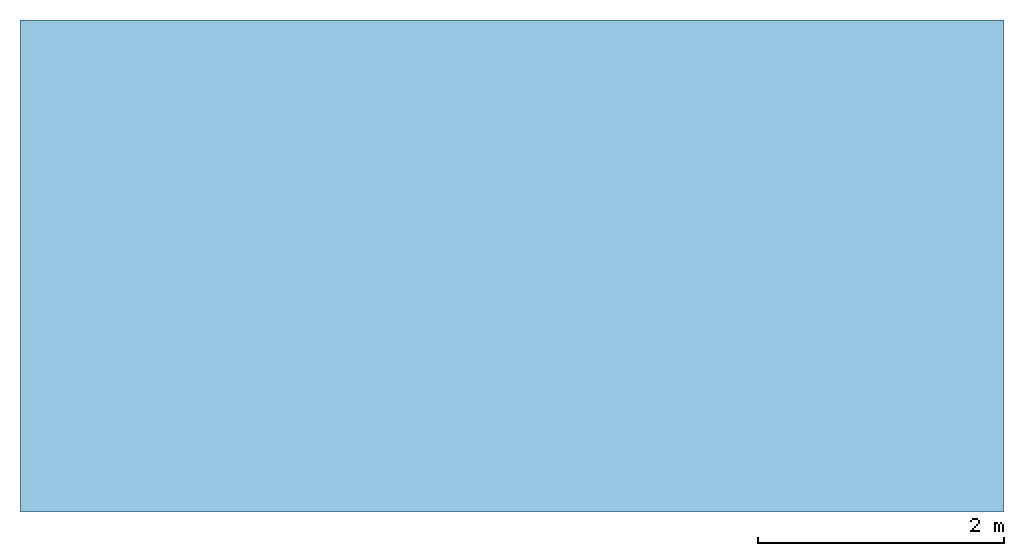
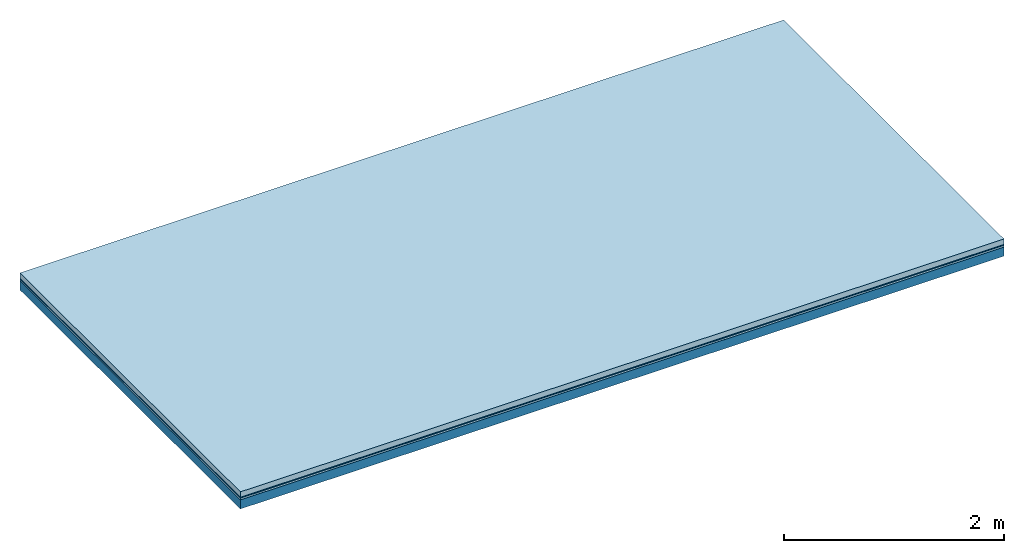
# One storey: 3 plates, 1 member, 1 element without a shape of its own.
"""IFC4 building model written with IfcOpenShell, lengths in metres."""

import ifcopenshell
import ifcopenshell.guid

model = None  # the IFC model being written
_history = None  # IfcOwnerHistory: only IFC2X3 demands one
_inside = {}  # id of a spatial element -> (the spatial element, [elements in it])
_under = {}  # id of a project, library or spatial element -> (it, [spatial elements below it])
_declared = {}  # id of a project -> (the project, [libraries it declares])
_typed = {}  # id of a type object -> (the type object, [elements of that type])
_made_of = {}  # id of a material, layer set ... -> (it, [elements and type objects made of it])


def new_model(schema):
    """Start an empty IFC model of exactly this schema.

    Asked for "IFC4X3", IfcOpenShell would pick the latest addendum, in which some entities
    have other attributes; the version numbers below select the first issue.
    IFC2X3 requires an IfcOwnerHistory on every rooted entity: one is made here for all.
    """
    global model, _history
    if schema == "IFC4X3":
        model = ifcopenshell.file(schema_version=(4, 3, 0, 0))
    else:
        model = ifcopenshell.file(schema=schema)
    _inside.clear()
    _under.clear()
    _declared.clear()
    _typed.clear()
    _made_of.clear()
    _history = None
    if model.schema == "IFC2X3":
        org = make("IfcOrganization", Name="unknown")
        user = make(
            "IfcPersonAndOrganization",
            ThePerson=make("IfcPerson", FamilyName="unknown"),
            TheOrganization=org,
        )
        app = make(
            "IfcApplication",
            ApplicationDeveloper=org,
            Version="unknown",
            ApplicationFullName="unknown",
            ApplicationIdentifier="unknown",
        )
        _history = make(
            "IfcOwnerHistory",
            OwningUser=user,
            OwningApplication=app,
            ChangeAction="ADDED",
            CreationDate=0,
        )
    return model


def make(cls, **values):
    """One entity of the class cls with the attributes given. An attribute that is None is left unset."""
    return model.create_entity(
        cls, **{name: value for name, value in values.items() if value is not None}
    )


def rooted(cls, **values):
    """An entity with a GlobalId (a new one), such as an element, a storey or a relation."""
    return make(cls, GlobalId=ifcopenshell.guid.new(), OwnerHistory=_history, **values)


def si_unit(unit_type, name, prefix=None):
    """IfcSIUnit, for example si_unit("LENGTHUNIT", "METRE", prefix="MILLI")."""
    return make("IfcSIUnit", UnitType=unit_type, Prefix=prefix, Name=name)


def derived_unit(unit_type, elements):
    """IfcDerivedUnit: a product of units, each with its exponent."""
    return make(
        "IfcDerivedUnit",
        Elements=[
            make("IfcDerivedUnitElement", Unit=unit, Exponent=power)
            for unit, power in elements
        ],
        UnitType=unit_type,
    )


def assignment(units):
    """IfcUnitAssignment: the units of a project."""
    return None if units is None else make("IfcUnitAssignment", Units=units)


def point(xyz):
    """IfcCartesianPoint."""
    return None if xyz is None else make("IfcCartesianPoint", Coordinates=xyz)


def direction(xyz):
    """IfcDirection."""
    return None if xyz is None else make("IfcDirection", DirectionRatios=xyz)


def frame(location, z_axis=None, x_axis=None):
    """IfcAxis2Placement3D, a coordinate frame: its origin and axes. An axis left out is left unset."""
    return make(
        "IfcAxis2Placement3D",
        Location=point(location),
        Axis=direction(z_axis),
        RefDirection=direction(x_axis),
    )


def frame_2d(location, x_axis=None):
    """IfcAxis2Placement2D, a coordinate frame in the plane: its origin and x axis."""
    return make(
        "IfcAxis2Placement2D", Location=point(location), RefDirection=direction(x_axis)
    )


def origin():
    """The frame at (0, 0, 0) with its axes left unset."""
    return frame((0.0, 0.0, 0.0))


def origin_with_axes():
    """The frame at (0, 0, 0) with the z axis (0, 0, 1) and the x axis (1, 0, 0) written out."""
    return frame((0.0, 0.0, 0.0), z_axis=(0.0, 0.0, 1.0), x_axis=(1.0, 0.0, 0.0))


def place(relative_to, where):
    """IfcLocalPlacement: puts the frame where relative to a parent placement (None: the world)."""
    return make(
        "IfcLocalPlacement", PlacementRelTo=relative_to, RelativePlacement=where
    )


def context(
    kind, dimensions, precision=None, world=None, true_north=None, identifier=None
):
    """IfcGeometricRepresentationContext, for example the 3D "Model" context."""
    return make(
        "IfcGeometricRepresentationContext",
        ContextIdentifier=identifier,
        ContextType=kind,
        CoordinateSpaceDimension=dimensions,
        Precision=precision,
        WorldCoordinateSystem=world,
        TrueNorth=true_north,
    )


def project(units=None, contexts=None):
    """IfcProject with its units and contexts."""
    return rooted(
        "IfcProject",
        Name="project",
        RepresentationContexts=contexts,
        UnitsInContext=assignment(units),
    )


def spatial(cls, under=None, at=None, **own):
    """A site, building, storey or space (cls), placed at a placement, below another one or the project."""
    s = rooted(cls, ObjectPlacement=at, **own)
    if under is not None:
        _under.setdefault(under.id(), (under, []))[1].append(s)
    return s


def profile(cls, at=None, kind="AREA", **sizes):
    """A parametric profile (cls). Its sizes go by their IFC names, for example OverallWidth=200.0."""
    return make(cls, ProfileType=kind, Position=at, **sizes)


def rectangle(**sizes):
    """IfcRectangleProfileDef."""
    return profile("IfcRectangleProfileDef", **sizes)


def extrude(swept, where, along, depth):
    """IfcExtrudedAreaSolid: the profile swept, set in the frame where, extruded along a direction by depth."""
    return make(
        "IfcExtrudedAreaSolid",
        SweptArea=swept,
        Position=where,
        ExtrudedDirection=direction(along),
        Depth=depth,
    )


def shape(context_of_items, identifier, shape_type, items):
    """IfcShapeRepresentation: the items that make up one representation, for example the "Body"."""
    return make(
        "IfcShapeRepresentation",
        ContextOfItems=context_of_items,
        RepresentationIdentifier=identifier,
        RepresentationType=shape_type,
        Items=items,
    )


def material(Name=None, Category=None):
    """IfcMaterial."""
    return make("IfcMaterial", Name=Name, Category=Category)


def layer(
    of_material, thickness, ventilated=None, Name=None, Category=None, Priority=None
):
    """IfcMaterialLayer: one layer of a wall or slab, of a material (None: an air gap)."""
    return make(
        "IfcMaterialLayer",
        Material=of_material,
        LayerThickness=thickness,
        IsVentilated=ventilated,
        Name=Name,
        Category=Category,
        Priority=Priority,
    )


def layer_set(layers, Name=None):
    """IfcMaterialLayerSet."""
    return make("IfcMaterialLayerSet", MaterialLayers=layers, LayerSetName=Name)


def made_of(thing, what):
    """Note that an element or type object is made of a material, layer set ...; save() writes the relation."""
    if what is not None:
        _made_of.setdefault(what.id(), (what, []))[1].append(thing)
    return thing


def type_object(cls, material=None, **own):
    """A type object (cls), such as IfcWallType, which elements share."""
    return made_of(rooted(cls, **own), material)


def element(
    cls,
    number,
    at=None,
    inside=None,
    cuts=None,
    type_object=None,
    material=None,
    context=None,
    identifier="Body",
    shape_type=None,
    held_by="IfcProductDefinitionShape",
    body=None,
    shapes=None,
    **own,
):
    """One element of the class cls, such as IfcWall. Its Tag is "e" and its number.

    at: its placement. inside: the storey or other place that contains it. cuts: it is an
    opening in that element (IfcRelVoidsElement). A single representation is given by context,
    identifier, shape_type and body (its items); several are given by shapes. held_by: the class
    of the entity that holds the representations. save() writes the other relations.
    """
    e = rooted(cls, Tag="e%d" % number, ObjectPlacement=at, **own)
    if body is not None:
        shapes = [shape(context, identifier, shape_type, body)]
    if shapes is not None:
        e.Representation = make(held_by, Representations=shapes)
    if inside is not None:
        _inside.setdefault(inside.id(), (inside, []))[1].append(e)
    if cuts is not None:
        rooted(
            "IfcRelVoidsElement", RelatingBuildingElement=cuts, RelatedOpeningElement=e
        )
    if type_object is not None:
        _typed.setdefault(type_object.id(), (type_object, []))[1].append(e)
    return made_of(e, material)


def aggregate(whole, parts):
    """IfcRelAggregates: a whole, such as a stair, and the parts it consists of."""
    return rooted("IfcRelAggregates", RelatingObject=whole, RelatedObjects=parts)


def save(model, path):
    """Write the relations noted so far, then the file.

    IfcRelAggregates (storeys below a building ...), IfcRelContainedInSpatialStructure (elements
    in a storey), IfcRelDefinesByType, IfcRelAssociatesMaterial and IfcRelDeclares: one each for
    every whole, place, type object, material and project.
    """
    for whole, parts in _under.values():
        aggregate(whole, parts)
    for where, things in _inside.values():
        rooted(
            "IfcRelContainedInSpatialStructure",
            RelatedElements=things,
            RelatingStructure=where,
        )
    for kind, things in _typed.values():
        rooted("IfcRelDefinesByType", RelatedObjects=things, RelatingType=kind)
    for what, things in _made_of.values():
        rooted("IfcRelAssociatesMaterial", RelatedObjects=things, RelatingMaterial=what)
    for by, libraries in _declared.values():
        rooted("IfcRelDeclares", RelatingContext=by, RelatedDefinitions=libraries)
    model.write(path)


model = new_model("IFC4")

# Units and contexts
plan_context = context("Plan", 3, precision=1e-05, world=origin(), true_north=direction((0.0, 1.0)))
model_context = context("Model", 3, precision=1e-05, world=origin(), true_north=direction((0.0, 1.0)))
ifc_project = project(units=[si_unit("LENGTHUNIT", "METRE"), derived_unit("SOUNDPRESSUREUNIT", [(si_unit("PRESSUREUNIT", "PASCAL", prefix="MICRO"), 0)]), si_unit("ENERGYUNIT", "JOULE", prefix="MEGA"), si_unit("MASSUNIT", "GRAM", prefix="KILO"), derived_unit("THERMALTRANSMITTANCEUNIT", [(si_unit("POWERUNIT", "WATT"), 1), (si_unit("AREAUNIT", "SQUARE_METRE"), -1), (si_unit("THERMODYNAMICTEMPERATUREUNIT", "KELVIN"), -1)]), derived_unit("AREADENSITYUNIT", [(si_unit("MASSUNIT", "GRAM", prefix="KILO"), 1), (si_unit("AREAUNIT", "SQUARE_METRE"), -1)]), derived_unit("USERDEFINED", [(si_unit("ENERGYUNIT", "JOULE", prefix="MEGA"), 1), (si_unit("AREAUNIT", "SQUARE_METRE"), -1)])], contexts=[plan_context, model_context])

# Site, building, storey
site = spatial("IfcSite", under=ifc_project)
building_placement = place(None, origin())
building = spatial("IfcBuilding", under=site, at=building_placement)
storey_placement = place(building_placement, origin())
storey = spatial("IfcBuildingStorey", under=building, at=storey_placement)

# Slab, member, plates
ifc_material_1 = material(Name="clay", Category="02.004")
ifc_layer_1 = layer(ifc_material_1, 0.06, Name="Use and protection layer 2")
ifc_material_2 = material(Name="Protective layer", Category="09.007")
ifc_layer_2 = layer(ifc_material_2, 0.01, Name="Use and protection layer 1")
ifc_material_3 = material(Name="Bituminous", Category="09.003")
ifc_layer_3 = layer(ifc_material_3, 0.02, Name="Seal")
ifc_material_4 = material(Name="no composite action")
ifc_layer_4 = layer(ifc_material_4, 0.0, Name="Bond")
ifc_layer_5 = layer(None, 0.1, Name="Support")
ifc_layer_set = layer_set([ifc_layer_1, ifc_layer_2, ifc_layer_3, ifc_layer_4, ifc_layer_5])
slab_type = type_object("IfcSlabType", Name="F0030", PredefinedType="NOTDEFINED", material=ifc_layer_set)
slab_placement = place(None, frame((0.0, 0.0, 0.0), z_axis=(0.0, 0.0, -1.0), x_axis=(1.0, 0.0, 0.0)))
slab = element("IfcSlab", 1, at=slab_placement, inside=storey, type_object=slab_type, material=ifc_layer_set, Name="Slab #1")
ifc_material_5 = material(Name="Solid timber panel")
member_placement = place(slab_placement, origin())
member = element("IfcMember", 2, at=member_placement, material=ifc_material_5, Name="Support", context=plan_context, shape_type="SweptSolid", body=[
    extrude(rectangle(XDim=1.0, YDim=0.1, at=frame_2d((0.5, 0.05), x_axis=(1.0, 0.0))), frame((0.0, 4.0, 0.09), z_axis=(0.0, -1.0, 0.0), x_axis=(1.0, 0.0, 0.0)), (0.0, 0.0, 1.0), 4.0),
    extrude(rectangle(XDim=1.0, YDim=0.1, at=frame_2d((0.5, 0.05), x_axis=(1.0, 0.0))), frame((1.0, 4.0, 0.09), z_axis=(0.0, -1.0, 0.0), x_axis=(1.0, 0.0, 0.0)), (0.0, 0.0, 1.0), 4.0),
    extrude(rectangle(XDim=1.0, YDim=0.1, at=frame_2d((0.5, 0.05), x_axis=(1.0, 0.0))), frame((2.0, 4.0, 0.09), z_axis=(0.0, -1.0, 0.0), x_axis=(1.0, 0.0, 0.0)), (0.0, 0.0, 1.0), 4.0),
    extrude(rectangle(XDim=1.0, YDim=0.1, at=frame_2d((0.5, 0.05), x_axis=(1.0, 0.0))), frame((3.0, 4.0, 0.09), z_axis=(0.0, -1.0, 0.0), x_axis=(1.0, 0.0, 0.0)), (0.0, 0.0, 1.0), 4.0),
    extrude(rectangle(XDim=1.0, YDim=0.1, at=frame_2d((0.5, 0.05), x_axis=(1.0, 0.0))), frame((4.0, 4.0, 0.09), z_axis=(0.0, -1.0, 0.0), x_axis=(1.0, 0.0, 0.0)), (0.0, 0.0, 1.0), 4.0),
    extrude(rectangle(XDim=1.0, YDim=0.1, at=frame_2d((0.5, 0.05), x_axis=(1.0, 0.0))), frame((5.0, 4.0, 0.09), z_axis=(0.0, -1.0, 0.0), x_axis=(1.0, 0.0, 0.0)), (0.0, 0.0, 1.0), 4.0),
    extrude(rectangle(XDim=1.0, YDim=0.1, at=frame_2d((0.5, 0.05), x_axis=(1.0, 0.0))), frame((6.0, 4.0, 0.09), z_axis=(0.0, -1.0, 0.0), x_axis=(1.0, 0.0, 0.0)), (0.0, 0.0, 1.0), 4.0),
    extrude(rectangle(XDim=1.0, YDim=0.1, at=frame_2d((0.5, 0.05), x_axis=(1.0, 0.0))), frame((7.0, 4.0, 0.09), z_axis=(0.0, -1.0, 0.0), x_axis=(1.0, 0.0, 0.0)), (0.0, 0.0, 1.0), 4.0),
])
plate_1_placement = place(slab_placement, origin())
plate_1 = element("IfcPlate", 3, at=plate_1_placement, material=ifc_material_1, Name="Use and protection layer 2", context=plan_context, shape_type="SweptSolid", body=[
    extrude(rectangle(XDim=8.0, YDim=4.0, at=frame_2d((4.0, 2.0), x_axis=(1.0, 0.0))), origin_with_axes(), (0.0, 0.0, 1.0), 0.06),
])
plate_2_placement = place(slab_placement, origin())
plate_2 = element("IfcPlate", 4, at=plate_2_placement, material=ifc_material_2, Name="Use and protection layer 1", context=plan_context, shape_type="SweptSolid", body=[
    extrude(rectangle(XDim=8.0, YDim=4.0, at=frame_2d((4.0, 2.0), x_axis=(1.0, 0.0))), frame((0.0, 0.0, 0.06), z_axis=(0.0, 0.0, 1.0), x_axis=(1.0, 0.0, 0.0)), (0.0, 0.0, 1.0), 0.01),
])
plate_3_placement = place(slab_placement, origin())
plate_3 = element("IfcPlate", 5, at=plate_3_placement, material=ifc_material_3, Name="Seal", context=plan_context, shape_type="SweptSolid", body=[
    extrude(rectangle(XDim=8.0, YDim=4.0, at=frame_2d((4.0, 2.0), x_axis=(1.0, 0.0))), frame((0.0, 0.0, 0.07), z_axis=(0.0, 0.0, 1.0), x_axis=(1.0, 0.0, 0.0)), (0.0, 0.0, 1.0), 0.02),
])
aggregate(slab, [plate_1, plate_2, plate_3, member])

save(model, "model.ifc")
